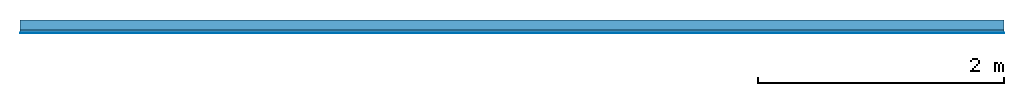
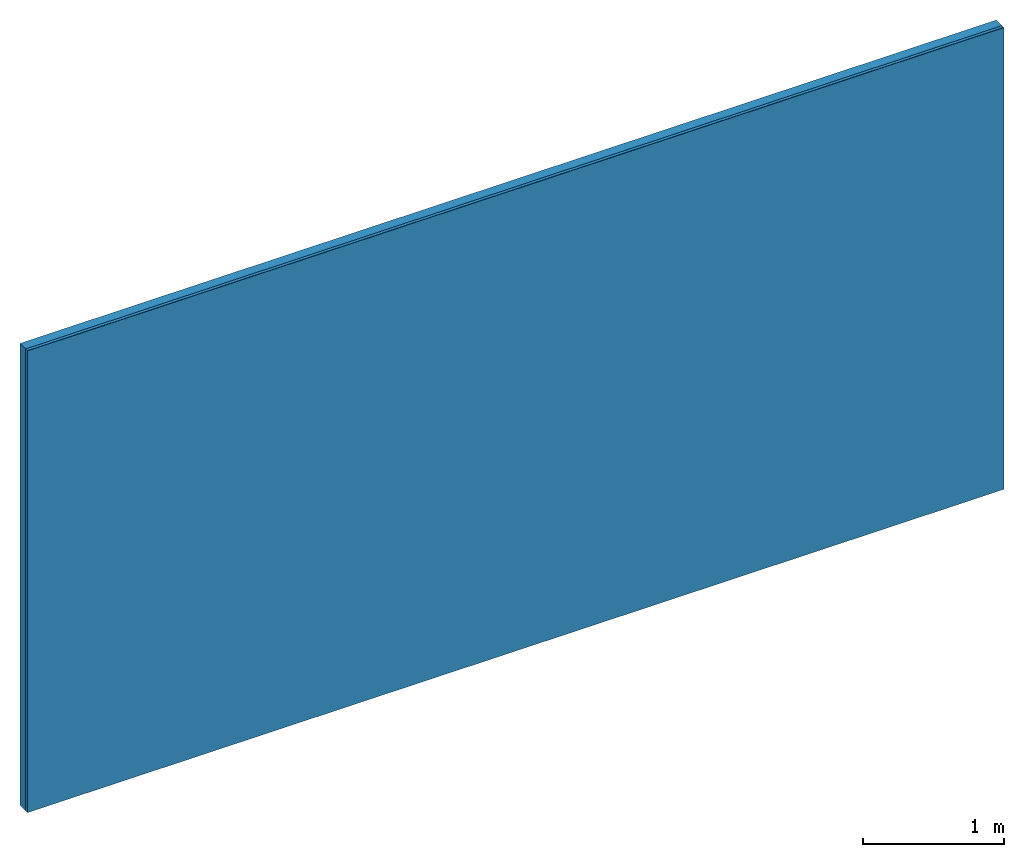
# One storey: 2 plates, 1 member, 1 element without a shape of its own.
"""IFC4 building model written with IfcOpenShell, lengths in metres."""

import ifcopenshell
import ifcopenshell.guid

model = None  # the IFC model being written
_history = None  # IfcOwnerHistory: only IFC2X3 demands one
_inside = {}  # id of a spatial element -> (the spatial element, [elements in it])
_under = {}  # id of a project, library or spatial element -> (it, [spatial elements below it])
_declared = {}  # id of a project -> (the project, [libraries it declares])
_typed = {}  # id of a type object -> (the type object, [elements of that type])
_made_of = {}  # id of a material, layer set ... -> (it, [elements and type objects made of it])


def new_model(schema):
    """Start an empty IFC model of exactly this schema.

    Asked for "IFC4X3", IfcOpenShell would pick the latest addendum, in which some entities
    have other attributes; the version numbers below select the first issue.
    IFC2X3 requires an IfcOwnerHistory on every rooted entity: one is made here for all.
    """
    global model, _history
    if schema == "IFC4X3":
        model = ifcopenshell.file(schema_version=(4, 3, 0, 0))
    else:
        model = ifcopenshell.file(schema=schema)
    _inside.clear()
    _under.clear()
    _declared.clear()
    _typed.clear()
    _made_of.clear()
    _history = None
    if model.schema == "IFC2X3":
        org = make("IfcOrganization", Name="unknown")
        user = make(
            "IfcPersonAndOrganization",
            ThePerson=make("IfcPerson", FamilyName="unknown"),
            TheOrganization=org,
        )
        app = make(
            "IfcApplication",
            ApplicationDeveloper=org,
            Version="unknown",
            ApplicationFullName="unknown",
            ApplicationIdentifier="unknown",
        )
        _history = make(
            "IfcOwnerHistory",
            OwningUser=user,
            OwningApplication=app,
            ChangeAction="ADDED",
            CreationDate=0,
        )
    return model


def make(cls, **values):
    """One entity of the class cls with the attributes given. An attribute that is None is left unset."""
    return model.create_entity(
        cls, **{name: value for name, value in values.items() if value is not None}
    )


def rooted(cls, **values):
    """An entity with a GlobalId (a new one), such as an element, a storey or a relation."""
    return make(cls, GlobalId=ifcopenshell.guid.new(), OwnerHistory=_history, **values)


def si_unit(unit_type, name, prefix=None):
    """IfcSIUnit, for example si_unit("LENGTHUNIT", "METRE", prefix="MILLI")."""
    return make("IfcSIUnit", UnitType=unit_type, Prefix=prefix, Name=name)


def derived_unit(unit_type, elements):
    """IfcDerivedUnit: a product of units, each with its exponent."""
    return make(
        "IfcDerivedUnit",
        Elements=[
            make("IfcDerivedUnitElement", Unit=unit, Exponent=power)
            for unit, power in elements
        ],
        UnitType=unit_type,
    )


def assignment(units):
    """IfcUnitAssignment: the units of a project."""
    return None if units is None else make("IfcUnitAssignment", Units=units)


def point(xyz):
    """IfcCartesianPoint."""
    return None if xyz is None else make("IfcCartesianPoint", Coordinates=xyz)


def direction(xyz):
    """IfcDirection."""
    return None if xyz is None else make("IfcDirection", DirectionRatios=xyz)


def frame(location, z_axis=None, x_axis=None):
    """IfcAxis2Placement3D, a coordinate frame: its origin and axes. An axis left out is left unset."""
    return make(
        "IfcAxis2Placement3D",
        Location=point(location),
        Axis=direction(z_axis),
        RefDirection=direction(x_axis),
    )


def frame_2d(location, x_axis=None):
    """IfcAxis2Placement2D, a coordinate frame in the plane: its origin and x axis."""
    return make(
        "IfcAxis2Placement2D", Location=point(location), RefDirection=direction(x_axis)
    )


def origin():
    """The frame at (0, 0, 0) with its axes left unset."""
    return frame((0.0, 0.0, 0.0))


def place(relative_to, where):
    """IfcLocalPlacement: puts the frame where relative to a parent placement (None: the world)."""
    return make(
        "IfcLocalPlacement", PlacementRelTo=relative_to, RelativePlacement=where
    )


def context(
    kind, dimensions, precision=None, world=None, true_north=None, identifier=None
):
    """IfcGeometricRepresentationContext, for example the 3D "Model" context."""
    return make(
        "IfcGeometricRepresentationContext",
        ContextIdentifier=identifier,
        ContextType=kind,
        CoordinateSpaceDimension=dimensions,
        Precision=precision,
        WorldCoordinateSystem=world,
        TrueNorth=true_north,
    )


def project(units=None, contexts=None):
    """IfcProject with its units and contexts."""
    return rooted(
        "IfcProject",
        Name="project",
        RepresentationContexts=contexts,
        UnitsInContext=assignment(units),
    )


def spatial(cls, under=None, at=None, **own):
    """A site, building, storey or space (cls), placed at a placement, below another one or the project."""
    s = rooted(cls, ObjectPlacement=at, **own)
    if under is not None:
        _under.setdefault(under.id(), (under, []))[1].append(s)
    return s


def profile(cls, at=None, kind="AREA", **sizes):
    """A parametric profile (cls). Its sizes go by their IFC names, for example OverallWidth=200.0."""
    return make(cls, ProfileType=kind, Position=at, **sizes)


def rectangle(**sizes):
    """IfcRectangleProfileDef."""
    return profile("IfcRectangleProfileDef", **sizes)


def extrude(swept, where, along, depth):
    """IfcExtrudedAreaSolid: the profile swept, set in the frame where, extruded along a direction by depth."""
    return make(
        "IfcExtrudedAreaSolid",
        SweptArea=swept,
        Position=where,
        ExtrudedDirection=direction(along),
        Depth=depth,
    )


def shape(context_of_items, identifier, shape_type, items):
    """IfcShapeRepresentation: the items that make up one representation, for example the "Body"."""
    return make(
        "IfcShapeRepresentation",
        ContextOfItems=context_of_items,
        RepresentationIdentifier=identifier,
        RepresentationType=shape_type,
        Items=items,
    )


def material(Name=None, Category=None):
    """IfcMaterial."""
    return make("IfcMaterial", Name=Name, Category=Category)


def layer(
    of_material, thickness, ventilated=None, Name=None, Category=None, Priority=None
):
    """IfcMaterialLayer: one layer of a wall or slab, of a material (None: an air gap)."""
    return make(
        "IfcMaterialLayer",
        Material=of_material,
        LayerThickness=thickness,
        IsVentilated=ventilated,
        Name=Name,
        Category=Category,
        Priority=Priority,
    )


def layer_set(layers, Name=None):
    """IfcMaterialLayerSet."""
    return make("IfcMaterialLayerSet", MaterialLayers=layers, LayerSetName=Name)


def made_of(thing, what):
    """Note that an element or type object is made of a material, layer set ...; save() writes the relation."""
    if what is not None:
        _made_of.setdefault(what.id(), (what, []))[1].append(thing)
    return thing


def type_object(cls, material=None, **own):
    """A type object (cls), such as IfcWallType, which elements share."""
    return made_of(rooted(cls, **own), material)


def element(
    cls,
    number,
    at=None,
    inside=None,
    cuts=None,
    type_object=None,
    material=None,
    context=None,
    identifier="Body",
    shape_type=None,
    held_by="IfcProductDefinitionShape",
    body=None,
    shapes=None,
    **own,
):
    """One element of the class cls, such as IfcWall. Its Tag is "e" and its number.

    at: its placement. inside: the storey or other place that contains it. cuts: it is an
    opening in that element (IfcRelVoidsElement). A single representation is given by context,
    identifier, shape_type and body (its items); several are given by shapes. held_by: the class
    of the entity that holds the representations. save() writes the other relations.
    """
    e = rooted(cls, Tag="e%d" % number, ObjectPlacement=at, **own)
    if body is not None:
        shapes = [shape(context, identifier, shape_type, body)]
    if shapes is not None:
        e.Representation = make(held_by, Representations=shapes)
    if inside is not None:
        _inside.setdefault(inside.id(), (inside, []))[1].append(e)
    if cuts is not None:
        rooted(
            "IfcRelVoidsElement", RelatingBuildingElement=cuts, RelatedOpeningElement=e
        )
    if type_object is not None:
        _typed.setdefault(type_object.id(), (type_object, []))[1].append(e)
    return made_of(e, material)


def aggregate(whole, parts):
    """IfcRelAggregates: a whole, such as a stair, and the parts it consists of."""
    return rooted("IfcRelAggregates", RelatingObject=whole, RelatedObjects=parts)


def save(model, path):
    """Write the relations noted so far, then the file.

    IfcRelAggregates (storeys below a building ...), IfcRelContainedInSpatialStructure (elements
    in a storey), IfcRelDefinesByType, IfcRelAssociatesMaterial and IfcRelDeclares: one each for
    every whole, place, type object, material and project.
    """
    for whole, parts in _under.values():
        aggregate(whole, parts)
    for where, things in _inside.values():
        rooted(
            "IfcRelContainedInSpatialStructure",
            RelatedElements=things,
            RelatingStructure=where,
        )
    for kind, things in _typed.values():
        rooted("IfcRelDefinesByType", RelatedObjects=things, RelatingType=kind)
    for what, things in _made_of.values():
        rooted("IfcRelAssociatesMaterial", RelatedObjects=things, RelatingMaterial=what)
    for by, libraries in _declared.values():
        rooted("IfcRelDeclares", RelatingContext=by, RelatedDefinitions=libraries)
    model.write(path)


model = new_model("IFC4")

# Units and contexts
plan_context = context("Plan", 3, precision=1e-05, world=origin(), true_north=direction((0.0, 1.0)))
model_context = context("Model", 3, precision=1e-05, world=origin(), true_north=direction((0.0, 1.0)))
ifc_project = project(units=[si_unit("LENGTHUNIT", "METRE"), derived_unit("SOUNDPRESSUREUNIT", [(si_unit("PRESSUREUNIT", "PASCAL", prefix="MICRO"), 0)]), si_unit("ENERGYUNIT", "JOULE", prefix="MEGA"), si_unit("MASSUNIT", "GRAM", prefix="KILO"), derived_unit("THERMALTRANSMITTANCEUNIT", [(si_unit("POWERUNIT", "WATT"), 1), (si_unit("AREAUNIT", "SQUARE_METRE"), -1), (si_unit("THERMODYNAMICTEMPERATUREUNIT", "KELVIN"), -1)]), derived_unit("AREADENSITYUNIT", [(si_unit("MASSUNIT", "GRAM", prefix="KILO"), 1), (si_unit("AREAUNIT", "SQUARE_METRE"), -1)]), derived_unit("USERDEFINED", [(si_unit("ENERGYUNIT", "JOULE", prefix="MEGA"), 1), (si_unit("AREAUNIT", "SQUARE_METRE"), -1)])], contexts=[plan_context, model_context])

# Site, building, storey
site = spatial("IfcSite", under=ifc_project)
building_placement = place(None, origin())
building = spatial("IfcBuilding", under=site, at=building_placement)
storey_placement = place(building_placement, origin())
storey = spatial("IfcBuildingStorey", under=building, at=storey_placement)

# Wall, member, plates
ifc_layer_1 = layer(None, 0.08, Name="Support")
ifc_material_1 = material(Name="of the art")
ifc_layer_2 = layer(ifc_material_1, 0.0, Name="Bond")
ifc_material_2 = material(Name="Clay panels")
ifc_layer_3 = layer(ifc_material_2, 0.025, Name="1st layer")
ifc_material_3 = material(Category="04.001")
ifc_layer_4 = layer(ifc_material_3, 0.003, Name="Surface")
ifc_layer_set = layer_set([ifc_layer_1, ifc_layer_2, ifc_layer_3, ifc_layer_4])
wall_type = type_object("IfcWallType", Name="C0355", PredefinedType="NOTDEFINED", material=ifc_layer_set)
wall_placement = place(None, frame((0.0, 0.0, 0.0), z_axis=(0.0, -1.0, 0.0), x_axis=(1.0, 0.0, 0.0)))
wall = element("IfcWall", 1, at=wall_placement, inside=storey, type_object=wall_type, material=ifc_layer_set, Name="Wall #1")
ifc_material_4 = material(Name="Solid timber panel")
member_placement = place(wall_placement, origin())
member = element("IfcMember", 2, at=member_placement, material=ifc_material_4, Name="Support", context=plan_context, shape_type="SweptSolid", body=[
    extrude(rectangle(XDim=1.0, YDim=0.08, at=frame_2d((0.5, 0.04), x_axis=(1.0, 0.0))), frame((0.0, 4.0, 0.0), z_axis=(0.0, -1.0, 0.0), x_axis=(1.0, 0.0, 0.0)), (0.0, 0.0, 1.0), 4.0),
    extrude(rectangle(XDim=1.0, YDim=0.08, at=frame_2d((0.5, 0.04), x_axis=(1.0, 0.0))), frame((1.0, 4.0, 0.0), z_axis=(0.0, -1.0, 0.0), x_axis=(1.0, 0.0, 0.0)), (0.0, 0.0, 1.0), 4.0),
    extrude(rectangle(XDim=1.0, YDim=0.08, at=frame_2d((0.5, 0.04), x_axis=(1.0, 0.0))), frame((2.0, 4.0, 0.0), z_axis=(0.0, -1.0, 0.0), x_axis=(1.0, 0.0, 0.0)), (0.0, 0.0, 1.0), 4.0),
    extrude(rectangle(XDim=1.0, YDim=0.08, at=frame_2d((0.5, 0.04), x_axis=(1.0, 0.0))), frame((3.0, 4.0, 0.0), z_axis=(0.0, -1.0, 0.0), x_axis=(1.0, 0.0, 0.0)), (0.0, 0.0, 1.0), 4.0),
    extrude(rectangle(XDim=1.0, YDim=0.08, at=frame_2d((0.5, 0.04), x_axis=(1.0, 0.0))), frame((4.0, 4.0, 0.0), z_axis=(0.0, -1.0, 0.0), x_axis=(1.0, 0.0, 0.0)), (0.0, 0.0, 1.0), 4.0),
    extrude(rectangle(XDim=1.0, YDim=0.08, at=frame_2d((0.5, 0.04), x_axis=(1.0, 0.0))), frame((5.0, 4.0, 0.0), z_axis=(0.0, -1.0, 0.0), x_axis=(1.0, 0.0, 0.0)), (0.0, 0.0, 1.0), 4.0),
    extrude(rectangle(XDim=1.0, YDim=0.08, at=frame_2d((0.5, 0.04), x_axis=(1.0, 0.0))), frame((6.0, 4.0, 0.0), z_axis=(0.0, -1.0, 0.0), x_axis=(1.0, 0.0, 0.0)), (0.0, 0.0, 1.0), 4.0),
    extrude(rectangle(XDim=1.0, YDim=0.08, at=frame_2d((0.5, 0.04), x_axis=(1.0, 0.0))), frame((7.0, 4.0, 0.0), z_axis=(0.0, -1.0, 0.0), x_axis=(1.0, 0.0, 0.0)), (0.0, 0.0, 1.0), 4.0),
])
plate_1_placement = place(wall_placement, origin())
plate_1 = element("IfcPlate", 3, at=plate_1_placement, material=ifc_material_2, Name="1st layer", context=plan_context, shape_type="SweptSolid", body=[
    extrude(rectangle(XDim=8.0, YDim=4.0, at=frame_2d((4.0, 2.0), x_axis=(1.0, 0.0))), frame((0.0, 0.0, 0.08), z_axis=(0.0, 0.0, 1.0), x_axis=(1.0, 0.0, 0.0)), (0.0, 0.0, 1.0), 0.025),
])
plate_2_placement = place(wall_placement, origin())
plate_2 = element("IfcPlate", 4, at=plate_2_placement, material=ifc_material_3, Name="Surface", context=plan_context, shape_type="SweptSolid", body=[
    extrude(rectangle(XDim=8.0, YDim=4.0, at=frame_2d((4.0, 2.0), x_axis=(1.0, 0.0))), frame((0.0, 0.0, 0.105), z_axis=(0.0, 0.0, 1.0), x_axis=(1.0, 0.0, 0.0)), (0.0, 0.0, 1.0), 0.003),
])
aggregate(wall, [member, plate_1, plate_2])

save(model, "model.ifc")
